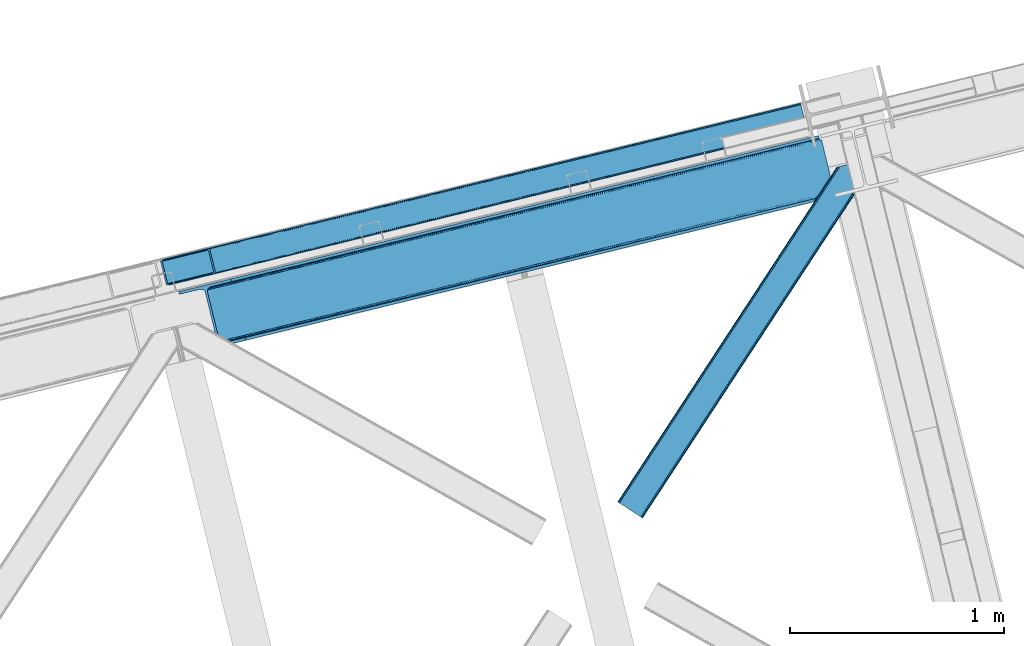
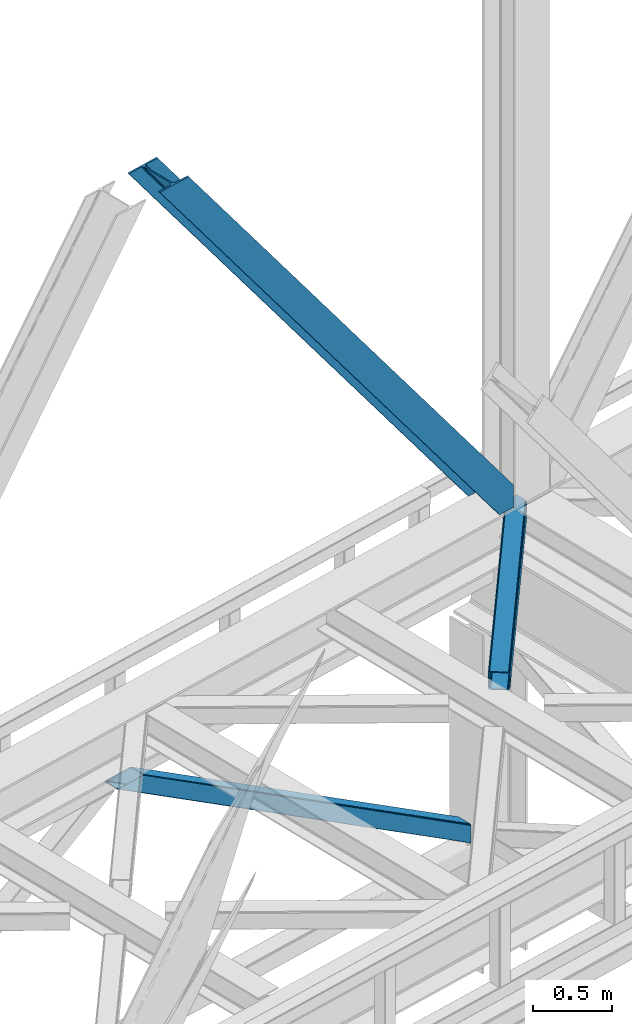
# One storey, part 50 of 92: 3 members.
"""IFC4 building model written with IfcOpenShell, lengths in millimetres."""

import ifcopenshell
import ifcopenshell.guid

model = None  # the IFC model being written
_history = None  # IfcOwnerHistory: only IFC2X3 demands one
_inside = {}  # id of a spatial element -> (the spatial element, [elements in it])
_under = {}  # id of a project, library or spatial element -> (it, [spatial elements below it])
_declared = {}  # id of a project -> (the project, [libraries it declares])
_typed = {}  # id of a type object -> (the type object, [elements of that type])
_made_of = {}  # id of a material, layer set ... -> (it, [elements and type objects made of it])


def new_model(schema):
    """Start an empty IFC model of exactly this schema.

    Asked for "IFC4X3", IfcOpenShell would pick the latest addendum, in which some entities
    have other attributes; the version numbers below select the first issue.
    IFC2X3 requires an IfcOwnerHistory on every rooted entity: one is made here for all.
    """
    global model, _history
    if schema == "IFC4X3":
        model = ifcopenshell.file(schema_version=(4, 3, 0, 0))
    else:
        model = ifcopenshell.file(schema=schema)
    _inside.clear()
    _under.clear()
    _declared.clear()
    _typed.clear()
    _made_of.clear()
    _history = None
    if model.schema == "IFC2X3":
        org = make("IfcOrganization", Name="unknown")
        user = make(
            "IfcPersonAndOrganization",
            ThePerson=make("IfcPerson", FamilyName="unknown"),
            TheOrganization=org,
        )
        app = make(
            "IfcApplication",
            ApplicationDeveloper=org,
            Version="unknown",
            ApplicationFullName="unknown",
            ApplicationIdentifier="unknown",
        )
        _history = make(
            "IfcOwnerHistory",
            OwningUser=user,
            OwningApplication=app,
            ChangeAction="ADDED",
            CreationDate=0,
        )
    return model


def make(cls, **values):
    """One entity of the class cls with the attributes given. An attribute that is None is left unset."""
    return model.create_entity(
        cls, **{name: value for name, value in values.items() if value is not None}
    )


def entity(cls, *values):
    """Any entity or typed value of the class cls, its attributes in the order of the schema. None: left unset."""
    e = model.create_entity(cls)
    for i, value in enumerate(values):
        if value is not None:
            e[i] = value
    return e


def rooted(cls, **values):
    """An entity with a GlobalId (a new one), such as an element, a storey or a relation."""
    return make(cls, GlobalId=ifcopenshell.guid.new(), OwnerHistory=_history, **values)


def si_unit(unit_type, name, prefix=None):
    """IfcSIUnit, for example si_unit("LENGTHUNIT", "METRE", prefix="MILLI")."""
    return make("IfcSIUnit", UnitType=unit_type, Prefix=prefix, Name=name)


def converted_unit(unit_type, name, factor, base, dimensions=None, offset=None):
    """IfcConversionBasedUnit, such as the inch: factor (a typed value) times the base unit."""
    return make(
        "IfcConversionBasedUnit"
        if offset is None
        else "IfcConversionBasedUnitWithOffset",
        ConversionOffset=offset,
        Dimensions=None
        if dimensions is None
        else entity("IfcDimensionalExponents", *dimensions),
        UnitType=unit_type,
        Name=name,
        ConversionFactor=make(
            "IfcMeasureWithUnit", ValueComponent=factor, UnitComponent=base
        ),
    )


def derived_unit(unit_type, elements):
    """IfcDerivedUnit: a product of units, each with its exponent."""
    return make(
        "IfcDerivedUnit",
        Elements=[
            make("IfcDerivedUnitElement", Unit=unit, Exponent=power)
            for unit, power in elements
        ],
        UnitType=unit_type,
    )


def assignment(units):
    """IfcUnitAssignment: the units of a project."""
    return None if units is None else make("IfcUnitAssignment", Units=units)


def point(xyz):
    """IfcCartesianPoint."""
    return None if xyz is None else make("IfcCartesianPoint", Coordinates=xyz)


def direction(xyz):
    """IfcDirection."""
    return None if xyz is None else make("IfcDirection", DirectionRatios=xyz)


def frame(location, z_axis=None, x_axis=None):
    """IfcAxis2Placement3D, a coordinate frame: its origin and axes. An axis left out is left unset."""
    return make(
        "IfcAxis2Placement3D",
        Location=point(location),
        Axis=direction(z_axis),
        RefDirection=direction(x_axis),
    )


def origin():
    """The frame at (0, 0, 0) with its axes left unset."""
    return frame((0.0, 0.0, 0.0))


def place(relative_to, where):
    """IfcLocalPlacement: puts the frame where relative to a parent placement (None: the world)."""
    return make(
        "IfcLocalPlacement", PlacementRelTo=relative_to, RelativePlacement=where
    )


def context(
    kind, dimensions, precision=None, world=None, true_north=None, identifier=None
):
    """IfcGeometricRepresentationContext, for example the 3D "Model" context."""
    return make(
        "IfcGeometricRepresentationContext",
        ContextIdentifier=identifier,
        ContextType=kind,
        CoordinateSpaceDimension=dimensions,
        Precision=precision,
        WorldCoordinateSystem=world,
        TrueNorth=true_north,
    )


def subcontext(parent, identifier, kind, view, scale=None):
    """IfcGeometricRepresentationSubContext, for example "Body" below "Model"."""
    return make(
        "IfcGeometricRepresentationSubContext",
        ContextIdentifier=identifier,
        ContextType=kind,
        ParentContext=parent,
        TargetScale=scale,
        TargetView=view,
    )


def project(units=None, contexts=None):
    """IfcProject with its units and contexts."""
    return rooted(
        "IfcProject",
        Name="project",
        RepresentationContexts=contexts,
        UnitsInContext=assignment(units),
    )


def spatial(cls, under=None, at=None, **own):
    """A site, building, storey or space (cls), placed at a placement, below another one or the project."""
    s = rooted(cls, ObjectPlacement=at, **own)
    if under is not None:
        _under.setdefault(under.id(), (under, []))[1].append(s)
    return s


def point_list(points):
    """IfcCartesianPointList2D or 3D."""
    cls = (
        "IfcCartesianPointList2D" if len(points[0]) == 2 else "IfcCartesianPointList3D"
    )
    return make(cls, CoordList=points)


def triangles(points, corners, closed=None, point_numbers=None):
    """IfcTriangulatedFaceSet: each triangle names its three corners, points numbered from 1."""
    return make(
        "IfcTriangulatedFaceSet",
        Coordinates=point_list(points),
        Closed=closed,
        CoordIndex=corners,
        PnIndex=point_numbers,
    )


def shape(context_of_items, identifier, shape_type, items):
    """IfcShapeRepresentation: the items that make up one representation, for example the "Body"."""
    return make(
        "IfcShapeRepresentation",
        ContextOfItems=context_of_items,
        RepresentationIdentifier=identifier,
        RepresentationType=shape_type,
        Items=items,
    )


def made_of(thing, what):
    """Note that an element or type object is made of a material, layer set ...; save() writes the relation."""
    if what is not None:
        _made_of.setdefault(what.id(), (what, []))[1].append(thing)
    return thing


def type_object(cls, material=None, **own):
    """A type object (cls), such as IfcWallType, which elements share."""
    return made_of(rooted(cls, **own), material)


def element(
    cls,
    number,
    at=None,
    inside=None,
    cuts=None,
    type_object=None,
    material=None,
    context=None,
    identifier="Body",
    shape_type=None,
    held_by="IfcProductDefinitionShape",
    body=None,
    shapes=None,
    **own,
):
    """One element of the class cls, such as IfcWall. Its Tag is "e" and its number.

    at: its placement. inside: the storey or other place that contains it. cuts: it is an
    opening in that element (IfcRelVoidsElement). A single representation is given by context,
    identifier, shape_type and body (its items); several are given by shapes. held_by: the class
    of the entity that holds the representations. save() writes the other relations.
    """
    e = rooted(cls, Tag="e%d" % number, ObjectPlacement=at, **own)
    if body is not None:
        shapes = [shape(context, identifier, shape_type, body)]
    if shapes is not None:
        e.Representation = make(held_by, Representations=shapes)
    if inside is not None:
        _inside.setdefault(inside.id(), (inside, []))[1].append(e)
    if cuts is not None:
        rooted(
            "IfcRelVoidsElement", RelatingBuildingElement=cuts, RelatedOpeningElement=e
        )
    if type_object is not None:
        _typed.setdefault(type_object.id(), (type_object, []))[1].append(e)
    return made_of(e, material)


def aggregate(whole, parts):
    """IfcRelAggregates: a whole, such as a stair, and the parts it consists of."""
    return rooted("IfcRelAggregates", RelatingObject=whole, RelatedObjects=parts)


def save(model, path):
    """Write the relations noted so far, then the file.

    IfcRelAggregates (storeys below a building ...), IfcRelContainedInSpatialStructure (elements
    in a storey), IfcRelDefinesByType, IfcRelAssociatesMaterial and IfcRelDeclares: one each for
    every whole, place, type object, material and project.
    """
    for whole, parts in _under.values():
        aggregate(whole, parts)
    for where, things in _inside.values():
        rooted(
            "IfcRelContainedInSpatialStructure",
            RelatedElements=things,
            RelatingStructure=where,
        )
    for kind, things in _typed.values():
        rooted("IfcRelDefinesByType", RelatedObjects=things, RelatingType=kind)
    for what, things in _made_of.values():
        rooted("IfcRelAssociatesMaterial", RelatedObjects=things, RelatingMaterial=what)
    for by, libraries in _declared.values():
        rooted("IfcRelDeclares", RelatingContext=by, RelatedDefinitions=libraries)
    model.write(path)


model = new_model("IFC4")

# Units and contexts
model_context = context("Model", 3, precision=0.01, world=origin(), true_north=direction((6.12303176911189e-17, 1.0)))
plan_context = context("Plan", 3, precision=0.01, world=origin(), true_north=direction((6.12303176911189e-17, 1.0)))
body_context = subcontext(model_context, "Body", "Model", "MODEL_VIEW")
ifc_project = project(units=[si_unit("LENGTHUNIT", "METRE", prefix="MILLI"), si_unit("AREAUNIT", "SQUARE_METRE"), si_unit("VOLUMEUNIT", "CUBIC_METRE"), converted_unit("PLANEANGLEUNIT", "DEGREE", entity("IfcRatioMeasure", 0.0174532925199433), si_unit("PLANEANGLEUNIT", "RADIAN"), dimensions=[0, 0, 0, 0, 0, 0, 0]), si_unit("MASSUNIT", "GRAM", prefix="KILO"), derived_unit("MASSDENSITYUNIT", [(si_unit("MASSUNIT", "GRAM", prefix="KILO"), 1), (si_unit("LENGTHUNIT", "METRE"), -3)]), derived_unit("MOMENTOFINERTIAUNIT", [(si_unit("LENGTHUNIT", "METRE"), 4)]), si_unit("TIMEUNIT", "SECOND"), si_unit("FREQUENCYUNIT", "HERTZ"), si_unit("THERMODYNAMICTEMPERATUREUNIT", "DEGREE_CELSIUS"), derived_unit("THERMALTRANSMITTANCEUNIT", [(si_unit("MASSUNIT", "GRAM", prefix="KILO"), 1), (si_unit("THERMODYNAMICTEMPERATUREUNIT", "KELVIN"), -1), (si_unit("TIMEUNIT", "SECOND"), -3)]), derived_unit("VOLUMETRICFLOWRATEUNIT", [(si_unit("LENGTHUNIT", "METRE"), 3), (si_unit("TIMEUNIT", "SECOND"), -1)]), derived_unit("MASSFLOWRATEUNIT", [(si_unit("MASSUNIT", "GRAM", prefix="KILO"), 1), (si_unit("TIMEUNIT", "SECOND"), -1)]), derived_unit("ROTATIONALFREQUENCYUNIT", [(si_unit("TIMEUNIT", "SECOND"), -1)]), si_unit("ELECTRICCURRENTUNIT", "AMPERE"), si_unit("ELECTRICVOLTAGEUNIT", "VOLT"), si_unit("POWERUNIT", "WATT"), si_unit("FORCEUNIT", "NEWTON", prefix="KILO"), si_unit("ILLUMINANCEUNIT", "LUX"), si_unit("LUMINOUSFLUXUNIT", "LUMEN"), si_unit("LUMINOUSINTENSITYUNIT", "CANDELA"), derived_unit("USERDEFINED", [(si_unit("MASSUNIT", "GRAM", prefix="KILO"), -1), (si_unit("LENGTHUNIT", "METRE"), -2), (si_unit("TIMEUNIT", "SECOND"), 3), (si_unit("LUMINOUSFLUXUNIT", "LUMEN"), 1)]), derived_unit("LINEARVELOCITYUNIT", [(si_unit("LENGTHUNIT", "METRE"), 1), (si_unit("TIMEUNIT", "SECOND"), -1)]), si_unit("PRESSUREUNIT", "PASCAL"), derived_unit("USERDEFINED", [(si_unit("LENGTHUNIT", "METRE"), -2), (si_unit("MASSUNIT", "GRAM", prefix="KILO"), 1), (si_unit("TIMEUNIT", "SECOND"), -2)]), derived_unit("LINEARFORCEUNIT", [(si_unit("MASSUNIT", "GRAM", prefix="KILO"), 1), (si_unit("LENGTHUNIT", "METRE"), 1), (si_unit("TIMEUNIT", "SECOND"), -2), (si_unit("LENGTHUNIT", "METRE"), -1)]), derived_unit("PLANARFORCEUNIT", [(si_unit("MASSUNIT", "GRAM", prefix="KILO"), 1), (si_unit("LENGTHUNIT", "METRE"), 1), (si_unit("TIMEUNIT", "SECOND"), -2), (si_unit("LENGTHUNIT", "METRE"), -2)])], contexts=[model_context, plan_context])

# Site, building, storey
site_placement = place(None, origin())
site = spatial("IfcSite", under=ifc_project, at=site_placement, CompositionType="ELEMENT")
building_placement = place(site_placement, origin())
building = spatial("IfcBuilding", under=site, at=building_placement, CompositionType="ELEMENT")
storey_placement = place(building_placement, frame((0.0, 0.0, 15900.0)))
storey = spatial("IfcBuildingStorey", under=building, at=storey_placement, Name="05", CompositionType="ELEMENT", Elevation=15900.0)

# Members
member_type_1 = type_object("IfcMemberType", PredefinedType="BRACE")
member_1_placement = place(storey_placement, frame((-39710.05, 10977.82, 3695.0)))
element("IfcMember", 1, at=member_1_placement, inside=storey, type_object=member_type_1, ObjectType="Steel Vertical Brace", PredefinedType="BRACE", context=body_context, shape_type="Tessellation", body=[
    triangles([(3067.37323608399, 755.491094970703, 0.827856445310317), (3068.03133544922, 754.507434082032, 1.13248901367115), (3066.60119018555, 754.045834350585, 0.0), (3064.68037719727, 761.925585937501, 0.0), (3064.21994018555, 752.730798339844, 7.29955444335792), (3064.21994018555, 752.730798339844, 0.0), (3060.00159301758, 741.228012084961, 0.0), (3059.68998413086, 743.591821289063, 30.563250732419), (3059.80625610352, 742.210510253906, 42.2602111816377), (3059.82020874024, 745.527749633789, 0.0), (3059.82020874024, 745.527749633789, 24.1799194335908), (3059.80625610352, 742.210510253906, 171.115136718749), (3060.00159301758, 741.228012084961, 171.175598144531), (3061.30151367188, 749.56936340332, 14.6921264648408), (3061.30151367188, 749.56936340332, 0.0), (3060.72247924805, 747.995040893555, 18.3872497558586), (215.726367187504, 48.9353851318356, 3911.00081176758), (310.455468749999, 72.0269989013668, 3911.00081176758), (192.839392089845, 54.7931671142578, 3911.00081176758), (198.973901367186, 50.2783264160153, 3911.00081176758), (207.010620117188, 48.2214752197269, 3911.00081176758), (189.537268066408, 61.0788299560554, 3911.00081176758), (3062.8432800293, 729.569421386719, 171.175598144531), (313.534350585942, 59.396374511718, 3911.00081176758), (3062.8432800293, 729.569421386719, 0.0), (2945.01326293946, 700.846755981445, 0.0), (69.865502929686, 0.0, 3911.00081176758), (2941.93438110351, 713.477380371094, 0.0), (66.78662109375, 12.6294616699215, 3911.00081176758), (161.511071777342, 35.7199127197273, 3911.00081176758), (3036.65883178711, 736.567831420898, 0.0), (3054.32752075195, 759.401321411133, 0.0), (3054.28798828125, 752.301754760741, 0.0), (179.17976074219, 58.5534027099602, 3911.00081176758), (179.142553710939, 51.4549987792961, 3911.00081176758), (3050.91842651367, 745.469613647461, 0.0), (175.770666503908, 44.622857666016, 3911.00081176758), (3044.72810668946, 739.944369506837, 0.0), (169.580346679686, 39.0976135253914, 3911.00081176758), (2999.1448425293, 985.772387695313, 0.0), (124.001733398436, 284.925631713868, 3911.00081176758), (2972.9510925293, 997.914669799804, 0.0), (2981.66916503906, 998.62974243164, 0.0), (106.523730468754, 297.781823730469, 3911.00081176758), (97.8079833984375, 297.067913818359, 3911.00081176758), (2989.70820922852, 996.572891235352, 0.0), (114.560449218749, 295.726135253906, 3911.00081176758), (2995.84504394532, 992.058050537109, 0.0), (120.699609374999, 291.211294555664, 3911.00081176758), (3.07888183593604, 273.977462768555, 3911.00081176758), (2878.22664184571, 974.82421875, 0.0), (2875.14776000976, 987.454843139649, 0.0), (0.0, 286.608087158203, 3911.00081176758), (3009.50002441406, 988.296652221679, 0.0), (134.354589843751, 287.449896240234, 3911.00081176758), (143.954003906249, 306.906848144532, 3911.00081176758), (243.668847656249, 346.004461669922, 3911.00081176758), (152.023278808592, 310.283386230469, 3911.00081176758), (137.763684082034, 301.381604003906, 3911.00081176758), (134.396447753905, 294.549462890625, 3911.00081176758), (246.747729492192, 333.373837280273, 3911.00081176758), (2992.98010253906, 1016.17750854492, 171.175598144531), (2992.98010253906, 1016.17750854492, 0.0), (2995.82178955078, 1004.51891784668, 171.175598144531), (2996.10084228516, 1003.55734863281, 171.115136718749), (2996.10084228516, 1003.55734863281, 42.2602111816377), (2995.82178955078, 1004.51891784668, 0.0), (3004.86077270508, 996.247329711914, 0.0), (2997.63795776368, 1000.61683044434, 0.0), (3000.81450805664, 997.712356567383, 0.0), (3007.57921142579, 996.175241088868, 0.0), (2996.63336791992, 1002.27719421387, 30.563250732419), (2997.80306396484, 1000.74124145508, 25.1542785644524), (2999.21228027344, 998.890191650391, 18.6337463378877), (3000.81450805664, 997.712356567383, 14.6921264648408), (3004.86077270508, 996.247329711914, 7.29955444335792), (3009.06051635742, 996.424063110351, 1.13248901367115), (3008.93029174805, 995.248553466798, 0.827856445310317)], [[1, 2, 3], [3, 4, 1], [5, 6, 3], [7, 8, 9], [7, 10, 11], [11, 8, 7], [9, 12, 13], [13, 7, 9], [14, 10, 15], [10, 14, 16], [11, 10, 16], [6, 5, 15], [14, 15, 5], [3, 2, 5], [17, 18, 12], [12, 9, 17], [1, 19, 5], [19, 20, 16], [16, 14, 19], [14, 5, 19], [20, 21, 8], [8, 11, 20], [9, 8, 21], [21, 17, 9], [11, 16, 20], [5, 2, 1], [1, 4, 19], [22, 19, 4], [13, 12, 18], [23, 13, 24], [18, 24, 13], [23, 25, 7], [7, 13, 23], [24, 26, 23], [24, 27, 26], [26, 25, 23], [28, 26, 29], [27, 29, 26], [29, 30, 28], [31, 28, 30], [32, 33, 34], [35, 34, 33], [33, 36, 35], [37, 35, 36], [36, 38, 37], [39, 37, 38], [38, 31, 39], [30, 39, 31], [40, 32, 34], [34, 41, 40], [42, 43, 44], [44, 45, 42], [43, 46, 47], [47, 44, 43], [46, 48, 49], [49, 47, 46], [48, 40, 41], [41, 49, 48], [45, 50, 51], [51, 42, 45], [52, 51, 50], [50, 53, 52], [4, 54, 55], [55, 22, 4], [41, 34, 55], [37, 39, 21], [30, 27, 24], [29, 27, 30], [39, 30, 17], [34, 35, 19], [35, 37, 20], [47, 56, 44], [53, 45, 57], [45, 44, 58], [53, 50, 45], [47, 49, 59], [49, 41, 60], [55, 34, 22], [17, 21, 39], [19, 35, 20], [21, 20, 37], [19, 22, 34], [24, 17, 30], [24, 18, 17], [58, 44, 56], [59, 49, 60], [55, 60, 41], [59, 56, 47], [58, 57, 45], [57, 58, 61], [57, 52, 53], [52, 57, 62], [63, 52, 62], [64, 62, 57], [65, 64, 61], [57, 61, 64], [61, 58, 65], [66, 65, 58], [64, 67, 62], [63, 62, 67], [32, 40, 54], [46, 43, 67], [42, 52, 63], [51, 52, 42], [43, 42, 63], [40, 48, 68], [48, 46, 69], [36, 7, 38], [26, 31, 25], [31, 38, 25], [26, 28, 31], [36, 33, 10], [33, 32, 6], [10, 7, 36], [54, 40, 68], [67, 69, 46], [63, 67, 43], [48, 69, 70], [70, 68, 48], [71, 54, 68], [32, 54, 4], [10, 33, 15], [33, 6, 15], [7, 25, 38], [32, 4, 6], [3, 6, 4], [67, 72, 73], [65, 66, 64], [67, 64, 66], [66, 72, 67], [69, 74, 75], [69, 73, 74], [76, 77, 71], [71, 68, 76], [76, 68, 70], [70, 75, 76], [75, 70, 69], [73, 69, 67], [60, 78, 76], [76, 59, 60], [76, 75, 59], [75, 74, 59], [78, 77, 76], [54, 78, 60], [60, 55, 54], [73, 59, 74], [59, 73, 72], [56, 59, 72], [72, 66, 56], [58, 56, 66], [77, 78, 71], [54, 71, 78]]),
])
member_type_2 = type_object("IfcMemberType", PredefinedType="BRACE")
member_2_placement = place(storey_placement, frame((-39794.77, 11294.57, 965.73)))
element("IfcMember", 2, at=member_2_placement, inside=storey, type_object=member_type_2, ObjectType="Steel Vertical Brace", PredefinedType="BRACE", context=body_context, shape_type="Tessellation", body=[
    triangles([(2980.25064697265, 840.910299682617, 4.31950378417969), (3005.96535644531, 734.986532592773, 4.46135559082177), (0.0, 110.814166259766, 1902.27458496094), (25.9333007812456, 4.94504699707068, 1902.27458496094), (2993.26380615234, 851.573602294922, 0.777859497069585), (7.35769042968604, 120.227545166015, 1902.27458496094), (12.8643310546831, 122.203005981446, 1902.27458496094), (2986.92233276367, 848.369146728515, 1.96848449706886), (2993.30101318359, 851.416635131836, 0.0), (2.98121337890188, 117.368417358399, 1902.27458496094), (2993.0870727539, 852.292163085938, 4.33810729980542), (2981.60870361328, 844.396133422852, 3.70675048827979), (0.39532470703125, 114.063967895509, 1902.27458496094), (3022.51783447265, 731.559997558594, 0.863900756834482), (3022.69224243164, 730.848413085938, 4.42647399902489), (42.611352539061, 0.792974853515261, 1902.27458496094), (36.8117065429688, 0.0, 1902.27458496094), (31.6073730468706, 0.510433959962029, 1902.27458496094), (3015.30432128906, 731.450701904298, 2.12545166015479), (3008.76751098633, 732.521566772461, 3.85557861328198), (27.7890014648438, 2.24753723144568, 1902.27458496094), (3022.48295288086, 731.707662963867, 0.126736450194585), (2993.0870727539, 852.292163085938, 132.50470275879), (214.121813964841, 171.505810546876, 1902.27458496094), (219.916809082031, 172.298785400391, 1902.27458496094), (2993.36612548828, 851.153860473632, 135.831243896486), (225.121142578122, 171.788351440429, 1902.27458496094), (2993.6428527832, 850.015557861328, 139.157785034178), (228.939514160156, 170.052410888673, 1902.27458496094), (2994.3125793457, 847.268051147461, 140.537933349609), (230.795214843747, 167.353738403321, 1902.27458496094), (2994.9823059082, 844.520544433593, 141.916918945313), (3020.79700927734, 738.621194458008, 141.994821166991), (256.728515625, 61.484619140625, 1902.27458496094), (3021.46673583984, 735.872525024415, 140.619323730469), (3022.13646240234, 733.125018310548, 139.243826293947), (256.333190917969, 58.2359802246101, 1902.27458496094), (3022.41318969726, 731.986715698242, 135.918447875978), (253.747302246091, 54.9303680419926, 1902.27458496094), (3022.69224243164, 730.848413085938, 132.593069458009), (249.370825195307, 52.0724029541016, 1902.27458496094), (243.86418457031, 50.0957794189453, 1902.27458496094), (2994.85905761718, 840.37196044922, 0.32439880371021), (3018.6855102539, 742.222137451172, 0.455786132813955), (3020.39703369141, 740.260629272461, 0.11743469238354), (2995.40553588867, 842.785766601563, 0.00930175781104481), (8.33437499999854, 108.738711547852, 1902.27458496094), (32.3701171875, 10.6388854980469, 1902.27458496094), (2994.71488037109, 845.623965454102, 3.0765563964851), (2994.18002929687, 847.814529418945, 5.44501647949073), (15.6967163085938, 118.150927734376, 1902.27458496094), (2995.25903320313, 843.390380859375, 0.662750244140625), (11.3155883789004, 115.292962646485, 1902.27458496094), (8.73435058593168, 111.987350463867, 1902.27458496094), (2994.03585205078, 848.406353759767, 9.04363403320167), (21.2033569335908, 120.127551269532, 1902.27458496094), (34.2211669921817, 7.94137573242188, 1902.27458496094), (3020.55516357422, 739.609506225586, 0.589498901368643), (38.0395385742158, 6.20427246093823, 1902.27458496094), (3021.19000854492, 737.010827636719, 2.47426757812354), (43.2438720703067, 5.6938385009762, 1902.27458496094), (3021.46673583984, 735.872525024415, 5.80080871581958), (49.0435180664063, 6.48797607421875, 1902.27458496094), (3021.74346313476, 734.734222412109, 9.12734985351563), (2994.03585205078, 848.406353759767, 127.803826904295), (207.684997558594, 165.811972045898, 1902.27458496094), (2995.26135864257, 843.382241821289, 135.837057495119), (2995.93108520508, 840.633572387696, 137.216043090819), (224.3583984375, 161.659899902344, 1902.27458496094), (2994.58930664062, 846.129748535157, 134.456909179688), (222.507348632811, 164.357409667969, 1902.27458496094), (2994.3125793457, 847.268051147461, 131.130368041991), (218.688977050777, 166.094512939453, 1902.27458496094), (213.484643554686, 166.604946899415, 1902.27458496094), (247.998815917963, 60.3114349365242, 1902.27458496094), (248.394140624994, 63.5600738525391, 1902.27458496094), (235.525158691402, 52.1712341308594, 1902.27458496094), (245.412927246092, 57.0069854736339, 1902.27458496094), (241.031799316406, 54.1478576660156, 1902.27458496094), (3021.46673583984, 735.872525024415, 131.211758422851), (3021.74346313476, 734.734222412109, 127.887542724609), (3021.19000854492, 737.010827636719, 134.53713684082), (3020.52028198242, 739.759497070312, 135.912634277345), (3019.85055541992, 742.50700378418, 137.288131713867)], [[1, 2, 3], [4, 3, 2], [5, 6, 7], [6, 5, 8], [5, 9, 8], [8, 10, 6], [7, 11, 5], [8, 12, 10], [13, 10, 12], [12, 1, 13], [3, 13, 1], [14, 15, 16], [17, 18, 19], [19, 14, 17], [2, 20, 21], [21, 4, 2], [20, 19, 18], [18, 21, 20], [19, 22, 14], [16, 17, 14], [23, 11, 24], [7, 24, 11], [23, 24, 25], [26, 25, 27], [28, 27, 29], [30, 29, 31], [31, 32, 30], [29, 30, 28], [27, 28, 26], [25, 26, 23], [33, 32, 31], [31, 34, 33], [35, 33, 34], [36, 35, 37], [38, 36, 39], [40, 38, 41], [41, 42, 40], [39, 41, 38], [37, 39, 36], [34, 37, 35], [15, 40, 42], [42, 16, 15], [43, 44, 1], [45, 19, 44], [45, 22, 19], [46, 8, 9], [8, 46, 43], [43, 12, 8], [2, 44, 20], [20, 44, 19], [44, 2, 1], [43, 1, 12], [44, 43, 47], [47, 48, 44], [49, 50, 51], [52, 49, 53], [54, 47, 43], [43, 46, 54], [46, 52, 54], [53, 54, 52], [51, 53, 49], [50, 55, 56], [56, 51, 50], [57, 45, 44], [57, 58, 45], [45, 57, 59], [60, 59, 61], [62, 61, 63], [63, 64, 62], [61, 62, 60], [59, 60, 45], [44, 48, 57], [55, 65, 66], [66, 56, 55], [67, 68, 69], [70, 67, 71], [72, 70, 73], [65, 72, 74], [74, 66, 65], [73, 74, 72], [71, 73, 70], [69, 71, 67], [71, 27, 25], [69, 34, 31], [29, 71, 31], [71, 29, 27], [71, 69, 31], [73, 71, 25], [66, 24, 7], [24, 73, 25], [74, 24, 66], [74, 73, 24], [39, 75, 41], [76, 34, 69], [34, 75, 37], [75, 34, 76], [39, 37, 75], [42, 77, 16], [41, 75, 78], [78, 79, 42], [79, 77, 42], [42, 41, 78], [53, 6, 54], [7, 56, 66], [7, 51, 56], [53, 7, 6], [53, 51, 7], [47, 3, 4], [54, 6, 10], [13, 54, 10], [54, 13, 3], [47, 54, 3], [17, 59, 57], [16, 77, 63], [63, 61, 16], [61, 59, 16], [17, 16, 59], [18, 17, 57], [4, 48, 47], [57, 4, 21], [4, 57, 48], [21, 18, 57], [80, 40, 81], [15, 62, 64], [81, 40, 15], [22, 60, 15], [64, 81, 15], [62, 15, 60], [45, 60, 22], [80, 38, 40], [82, 35, 36], [38, 80, 82], [36, 38, 82], [83, 33, 35], [35, 82, 83], [33, 84, 32], [84, 33, 83], [65, 23, 72], [49, 9, 50], [52, 9, 49], [55, 23, 65], [11, 55, 50], [50, 9, 11], [55, 11, 23], [72, 26, 70], [67, 30, 32], [70, 30, 67], [68, 32, 84], [32, 68, 67], [70, 28, 30], [26, 72, 23], [26, 28, 70], [68, 84, 69], [76, 69, 84], [81, 77, 79], [80, 79, 78], [82, 78, 75], [83, 75, 76], [76, 84, 83], [75, 83, 82], [78, 82, 80], [79, 80, 81], [81, 64, 77], [63, 77, 64]]),
])
member_type_3 = type_object("IfcMemberType", PredefinedType="BRACE")
member_3_placement = place(storey_placement, frame((-37656.9, 10204.55, 3511.0)))
element("IfcMember", 3, at=member_3_placement, inside=storey, type_object=member_type_3, ObjectType="Steel Horizontal Brace", PredefinedType="BRACE", context=body_context, shape_type="Tessellation", body=[
    triangles([(994.774163818358, 1564.02662658691, 0.0), (1028.82324829102, 1424.34678039551, 0.0), (14.643292236331, 67.1040435791019, 0.0), (102.486767578128, 9.58662414550781, 0.0), (1.1162109375, 75.9604797363281, 10.8028289794929), (0.0, 76.6895050048824, 17.5000946044929), (1025.02813110351, 1642.17883300781, 17.5000946044929), (4.29043579101563, 73.8826995849613, 5.12526855468968), (990.476751708986, 1585.87645568848, 9.50058288574292), (990.046545410158, 1584.44747314453, 8.74132690429906), (989.90701904297, 1583.99168701172, 8.50064392089917), (990.762780761717, 1580.48841247559, 5.12526855468968), (1027.31171264649, 1642.73461303711, 10.8702667236357), (1027.78377685547, 1642.84972229004, 9.50058288574292), (992.602203369141, 1572.93538513184, 1.33247680664135), (9.04130859374709, 70.7724243164066, 1.33247680664135), (1025.02813110351, 1642.17883300781, 122.500662231447), (0.0, 76.6895050048824, 122.500662231447), (1026.92336425781, 1642.64043273926, 129.197927856447), (1.1162109375, 75.9604797363281, 129.197927856447), (1032.31838378906, 1643.95546875, 134.874325561526), (4.29043579101563, 73.8826995849613, 134.874325561526), (1040.39463500977, 1645.92395324707, 138.667117309571), (9.04130859374709, 70.7724243164066, 138.667117309571), (1049.91963500976, 1648.24590454102, 139.999594116212), (14.643292236331, 67.1040435791019, 139.999594116212), (994.871832275392, 1567.85081176758, 9.50058288574292), (994.762536621092, 1567.00667724609, 9.29478149414354), (994.650915527345, 1566.15091552734, 9.08781738281323), (994.541619873045, 1565.30561828613, 8.8831787109375), (994.746258544925, 1564.1440612793, 8.50064392089917), (1047.05469360352, 1647.54827270508, 9.50058288574292), (14.8967651367202, 66.9377746582031, 8.3320495605476), (20.4987487792969, 63.2693939208984, 6.99957275390625), (997.043792724609, 1554.71440429688, 6.99957275390625), (10.1458923339815, 70.0480499267578, 12.1260040283232), (1042.27591552735, 1646.38322753906, 12.1260040283232), (1036.87857055664, 1645.06702880859, 17.8035644531265), (1034.9856628418, 1644.60542907715, 24.4996673583992), (6.97166748046584, 72.1258300781246, 17.8035644531265), (5.85778198242042, 72.8548553466808, 24.4996673583992), (1026.55361938477, 1433.65900268555, 6.99957275390625), (96.6313110351548, 13.420111083984, 6.99957275390625), (1028.71860351563, 1424.77582397461, 8.41343994140698), (1032.83695678711, 1407.88615722656, 5.12526855468968), (1033.6903930664, 1404.3817199707, 8.50064392089917), (1030.99520874023, 1415.43918457031, 1.33247680664135), (1034.9856628418, 1644.60542907715, 115.501089477541), (5.85778198242042, 72.8548553466808, 115.501089477541), (1050.34984130859, 1648.35171203613, 131.667544555665), (1059.87716674805, 1650.67366333008, 133.000021362306), (20.4987487792969, 63.2693939208984, 133.000021362306), (14.8967651367202, 66.9377746582031, 131.667544555665), (1042.27591552735, 1646.38322753906, 127.87475280762), (10.1458923339815, 70.0480499267578, 127.87475280762), (1036.87857055664, 1645.06702880859, 122.196029663086), (6.97166748046584, 72.1258300781246, 122.196029663086), (1128.10788574219, 1667.30520629883, 139.999594116212), (1128.10788574219, 1667.30520629883, 133.000021362306), (1144.33015136719, 1600.75810546875, 139.999594116212), (102.486767578128, 9.58662414550781, 139.999594116212), (1142.06052246094, 1610.06916503906, 133.000021362306), (96.6313110351548, 13.420111083984, 133.000021362306), (1146.50211181641, 1591.84934692383, 138.667117309571), (108.088751220705, 5.91708068847765, 138.667117309571), (1148.34385986328, 1584.29631958008, 134.874325561526), (112.839624023436, 2.80796813964844, 134.874325561526), (1149.57401733399, 1579.2501159668, 129.197927856447), (116.013848876952, 0.729025268554324, 129.197927856447), (1150.00422363282, 1577.47813110352, 122.500662231447), (117.127734374997, 0.0, 122.500662231447), (1150.00422363282, 1577.47813110352, 17.5000946044929), (117.127734374997, 0.0, 17.5000946044929), (106.98416748047, 6.64261779785193, 127.87475280762), (110.156066894531, 4.56367492675781, 122.196029663086), (111.269952392577, 3.83464965820349, 115.501089477541), (102.233294677731, 9.75173034667932, 131.667544555665), (116.013848876952, 0.729025268554324, 10.8028289794929), (106.98416748047, 6.64261779785193, 12.1260040283232), (112.839624023436, 2.80796813964844, 5.12526855468968), (111.269952392577, 3.83464965820349, 24.4996673583992), (110.156066894531, 4.56367492675781, 17.8035644531265), (108.088751220705, 5.91708068847765, 1.33247680664135), (102.233294677731, 9.75173034667932, 8.3320495605476), (1147.30438842774, 1588.56233825684, 122.196029663086), (1147.73459472656, 1586.78919067383, 115.501089477541), (1146.07423095703, 1593.60854187012, 127.87475280762), (1144.23248291016, 1601.16040649414, 131.667544555665), (1147.73459472656, 1586.78919067383, 24.4996673583992), (1147.21602172851, 1588.9239440918, 17.869839477542), (1149.994921875, 1577.51650085449, 16.5001556396492), (1147.10672607422, 1589.36461486816, 16.5001556396492), (1145.27893066406, 1573.10863037109, 10.8714294433594), (1034.62056884765, 1404.78750915527, 9.50058288574292), (1144.12783813477, 1572.03427734375, 9.50058288574292), (1142.79303588867, 1588.59721984863, 12.1260040283232), (1030.22548828125, 1422.8143157959, 9.50058288574292), (1029.19764404297, 1423.6724029541, 8.80643920898729), (1139.73275756836, 1590.05992126465, 9.50058288574292)], [[1, 2, 3], [4, 3, 2], [5, 6, 7], [8, 9, 10], [11, 12, 8], [5, 13, 9], [9, 8, 5], [13, 14, 9], [15, 1, 16], [3, 16, 1], [12, 15, 8], [16, 8, 15], [7, 13, 5], [17, 7, 6], [6, 18, 17], [19, 17, 20], [18, 20, 17], [21, 19, 22], [20, 22, 19], [23, 21, 24], [22, 24, 21], [25, 23, 26], [24, 26, 23], [27, 28, 9], [28, 29, 10], [29, 30, 10], [30, 31, 11], [14, 32, 27], [27, 9, 14], [33, 34, 35], [36, 33, 31], [31, 30, 36], [28, 36, 29], [28, 27, 36], [36, 30, 29], [32, 37, 27], [36, 27, 37], [35, 31, 33], [38, 39, 40], [41, 40, 39], [37, 38, 36], [40, 36, 38], [42, 35, 34], [34, 43, 42], [1, 35, 42], [31, 12, 11], [1, 31, 35], [31, 15, 12], [31, 1, 15], [2, 1, 42], [44, 2, 42], [45, 44, 46], [44, 47, 2], [44, 45, 47], [39, 48, 41], [49, 41, 48], [50, 51, 52], [52, 53, 50], [54, 50, 53], [53, 55, 54], [56, 54, 55], [55, 57, 56], [48, 56, 57], [57, 49, 48], [56, 17, 19], [50, 23, 25], [58, 51, 25], [51, 58, 59], [51, 50, 25], [54, 23, 50], [54, 56, 21], [21, 23, 54], [19, 21, 56], [39, 7, 17], [37, 14, 38], [56, 48, 17], [37, 32, 14], [39, 38, 7], [48, 39, 17], [13, 7, 38], [38, 14, 13], [60, 25, 61], [25, 60, 58], [26, 61, 25], [51, 62, 63], [51, 59, 62], [63, 52, 51], [64, 60, 61], [61, 65, 64], [66, 64, 65], [65, 67, 66], [68, 66, 67], [67, 69, 68], [70, 68, 69], [69, 71, 70], [72, 70, 71], [71, 73, 72], [69, 74, 75], [76, 73, 71], [69, 75, 71], [69, 67, 74], [75, 76, 71], [74, 67, 65], [63, 61, 26], [61, 77, 65], [77, 61, 63], [77, 74, 65], [78, 79, 80], [81, 73, 76], [73, 82, 78], [82, 73, 81], [78, 82, 79], [4, 43, 3], [83, 80, 79], [79, 84, 83], [84, 43, 4], [4, 83, 84], [55, 24, 22], [26, 52, 63], [26, 53, 52], [53, 26, 24], [55, 53, 24], [49, 18, 6], [20, 57, 55], [22, 20, 55], [57, 20, 18], [49, 57, 18], [16, 36, 8], [3, 43, 34], [34, 33, 3], [33, 36, 16], [16, 3, 33], [5, 8, 36], [6, 41, 49], [40, 6, 5], [6, 40, 41], [40, 5, 36], [85, 86, 75], [76, 75, 86], [87, 85, 74], [75, 74, 85], [88, 87, 77], [74, 77, 87], [62, 88, 63], [77, 63, 88], [86, 89, 81], [81, 76, 86], [90, 91, 92], [70, 72, 89], [72, 90, 89], [89, 86, 70], [72, 91, 90], [85, 70, 86], [68, 70, 85], [66, 85, 87], [85, 66, 68], [87, 64, 66], [88, 64, 87], [88, 62, 60], [88, 60, 64], [62, 58, 60], [62, 59, 58], [73, 78, 93], [93, 72, 73], [94, 93, 78], [94, 95, 93], [80, 45, 46], [46, 78, 80], [46, 94, 78], [47, 45, 83], [80, 83, 45], [2, 47, 4], [83, 4, 47], [93, 91, 72], [82, 81, 89], [82, 92, 96], [82, 90, 92], [84, 97, 98], [79, 96, 97], [97, 84, 79], [96, 99, 97], [43, 84, 44], [44, 42, 43], [96, 79, 82], [89, 90, 82], [96, 91, 93], [96, 92, 91], [96, 95, 99], [93, 95, 96], [99, 95, 97], [94, 97, 95]]),
])

save(model, "model.ifc")
